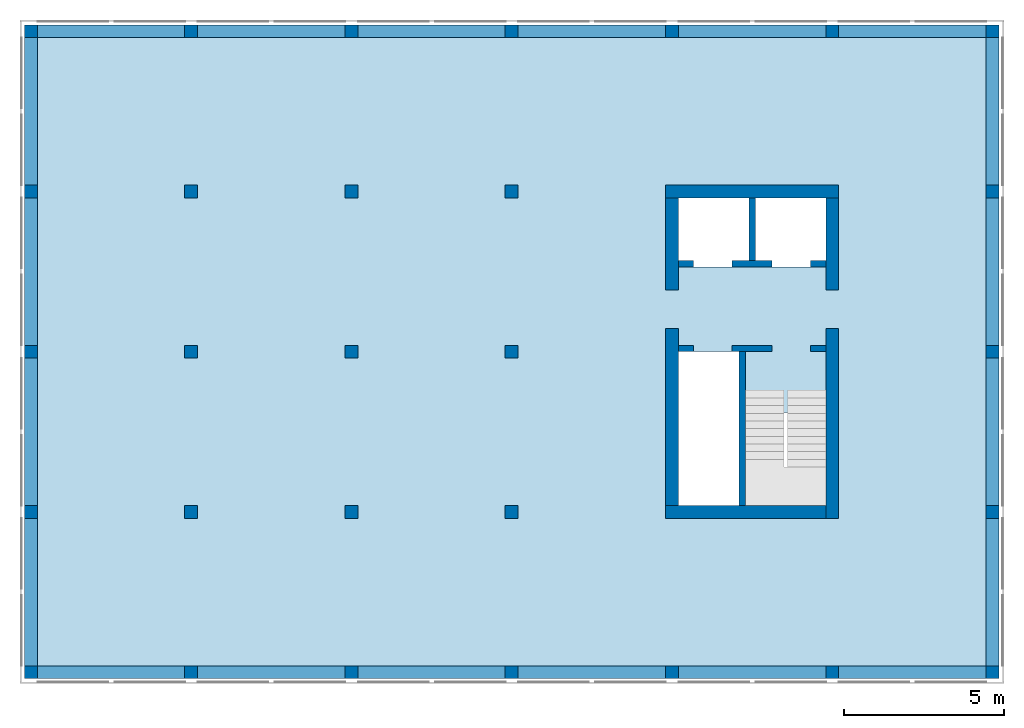
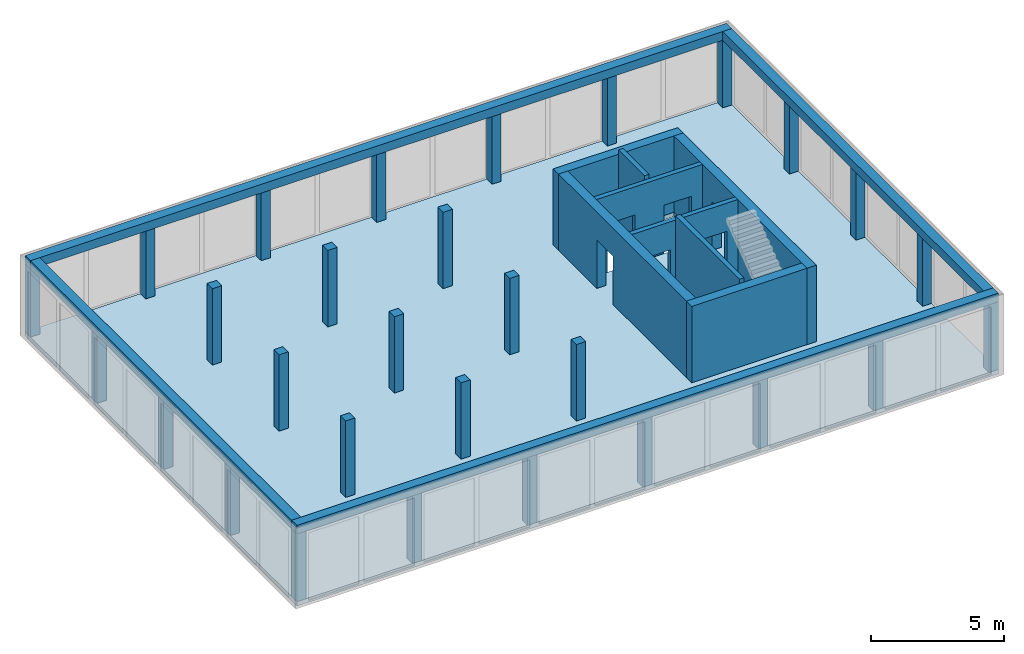
# One storey, part 1 of 4: 29 columns, 8 walls, 4 beams, 1 slab, 9 openings.
"""IFC2X3 building model written with IfcOpenShell, lengths in metres."""

from ifc_helpers import new_model, entity, si_unit, converted_unit, frame, frame_2d, origin, origin_with_axes, place, context, subcontext, project, spatial, polyline, rectangle, outline, extrude, material, layer, layer_set, layer_usage, element, save


model = new_model("IFC2X3")

# Units and contexts
model_context = context("Model", 3, precision=1e-05, world=origin())
body_context = subcontext(model_context, "Body", "Model", "MODEL_VIEW")
ifc_project = project(units=[si_unit("LENGTHUNIT", "METRE"), si_unit("AREAUNIT", "SQUARE_METRE"), si_unit("VOLUMEUNIT", "CUBIC_METRE"), si_unit("MASSUNIT", "GRAM", prefix="KILO"), converted_unit("PLANEANGLEUNIT", "DEGREE", entity("IfcPlaneAngleMeasure", 0.0174532925199433), si_unit("PLANEANGLEUNIT", "RADIAN"), dimensions=[0, 0, 0, 0, 0, 0, 0])], contexts=[model_context])

# Site, building, storey
site_placement = place(None, origin())
site = spatial("IfcSite", under=ifc_project, at=site_placement, CompositionType="ELEMENT")
building_placement = place(site_placement, origin())
building = spatial("IfcBuilding", under=site, at=building_placement, CompositionType="ELEMENT")
storey_placement = place(building_placement, frame((0.0, 0.0, 4.9)))
storey = spatial("IfcBuildingStorey", under=building, at=storey_placement, Name="1. Obergeschoss", CompositionType="ELEMENT", Elevation=4.9)

# Columns
ifc_material_1 = material(Name="C30/37")
column_1_placement = place(storey_placement, frame((5.0, 15.0, 0.0)))
element("IfcColumn", 1, at=column_1_placement, inside=storey, material=ifc_material_1, context=body_context, shape_type="SweptSolid", body=[
    extrude(rectangle(XDim=0.4, YDim=0.4, at=frame_2d((0.2, 0.2), x_axis=(1.0, 0.0))), origin_with_axes(), (0.0, 0.0, 1.0), 3.5),
])
ifc_material_2 = material(Name="C30/37")
column_2_placement = place(storey_placement, frame((10.0, 5.0, 0.0)))
element("IfcColumn", 2, at=column_2_placement, inside=storey, material=ifc_material_2, context=body_context, shape_type="SweptSolid", body=[
    extrude(rectangle(XDim=0.4, YDim=0.4, at=frame_2d((0.2, 0.2), x_axis=(1.0, 0.0))), origin_with_axes(), (0.0, 0.0, 1.0), 3.5),
])
ifc_material_3 = material(Name="C30/37")
column_3_placement = place(storey_placement, frame((15.0, 5.0, 0.0)))
element("IfcColumn", 3, at=column_3_placement, inside=storey, material=ifc_material_3, context=body_context, shape_type="SweptSolid", body=[
    extrude(rectangle(XDim=0.4, YDim=0.4, at=frame_2d((0.2, 0.2), x_axis=(1.0, 0.0))), origin_with_axes(), (0.0, 0.0, 1.0), 3.5),
])
ifc_material_4 = material(Name="C30/37")
column_4_placement = place(storey_placement, frame((5.0, 10.0, 0.0)))
element("IfcColumn", 4, at=column_4_placement, inside=storey, material=ifc_material_4, context=body_context, shape_type="SweptSolid", body=[
    extrude(rectangle(XDim=0.4, YDim=0.4, at=frame_2d((0.2, 0.2), x_axis=(1.0, 0.0))), origin_with_axes(), (0.0, 0.0, 1.0), 3.5),
])
ifc_material_5 = material(Name="C30/37")
column_5_placement = place(storey_placement, frame((10.0, 10.0, 0.0)))
element("IfcColumn", 5, at=column_5_placement, inside=storey, material=ifc_material_5, context=body_context, shape_type="SweptSolid", body=[
    extrude(rectangle(XDim=0.4, YDim=0.4, at=frame_2d((0.2, 0.2), x_axis=(1.0, 0.0))), origin_with_axes(), (0.0, 0.0, 1.0), 3.5),
])
ifc_material_6 = material(Name="C30/37")
column_6_placement = place(storey_placement, frame((15.0, 10.0, 0.0)))
element("IfcColumn", 6, at=column_6_placement, inside=storey, material=ifc_material_6, context=body_context, shape_type="SweptSolid", body=[
    extrude(rectangle(XDim=0.4, YDim=0.4, at=frame_2d((0.2, 0.2), x_axis=(1.0, 0.0))), origin_with_axes(), (0.0, 0.0, 1.0), 3.5),
])
ifc_material_7 = material(Name="C30/37")
column_7_placement = place(storey_placement, frame((10.0, 15.0, 0.0)))
element("IfcColumn", 7, at=column_7_placement, inside=storey, material=ifc_material_7, context=body_context, shape_type="SweptSolid", body=[
    extrude(rectangle(XDim=0.4, YDim=0.4, at=frame_2d((0.2, 0.2), x_axis=(1.0, 0.0))), origin_with_axes(), (0.0, 0.0, 1.0), 3.5),
])
ifc_material_8 = material(Name="C30/37")
column_8_placement = place(storey_placement, frame((15.0, 15.0, 0.0)))
element("IfcColumn", 8, at=column_8_placement, inside=storey, material=ifc_material_8, context=body_context, shape_type="SweptSolid", body=[
    extrude(rectangle(XDim=0.4, YDim=0.4, at=frame_2d((0.2, 0.2), x_axis=(1.0, 0.0))), origin_with_axes(), (0.0, 0.0, 1.0), 3.5),
])
ifc_material_9 = material(Name="C30/37")
column_9_placement = place(storey_placement, frame((5.0, 5.0, 0.0)))
element("IfcColumn", 9, at=column_9_placement, inside=storey, material=ifc_material_9, context=body_context, shape_type="SweptSolid", body=[
    extrude(rectangle(XDim=0.4, YDim=0.4, at=frame_2d((0.2, 0.2), x_axis=(1.0, 0.0))), origin_with_axes(), (0.0, 0.0, 1.0), 3.5),
])
ifc_material_10 = material(Name="C30/37")
column_10_placement = place(storey_placement, frame((30.0, 5.0, 0.0)))
element("IfcColumn", 10, at=column_10_placement, inside=storey, material=ifc_material_10, context=body_context, shape_type="SweptSolid", body=[
    extrude(rectangle(XDim=0.4, YDim=0.4, at=frame_2d((0.2, 0.2), x_axis=(1.0, 0.0))), origin_with_axes(), (0.0, 0.0, 1.0), 3.1),
])
ifc_material_11 = material(Name="C30/37")
column_11_placement = place(storey_placement, frame((30.0, 20.0, 0.0)))
element("IfcColumn", 11, at=column_11_placement, inside=storey, material=ifc_material_11, context=body_context, shape_type="SweptSolid", body=[
    extrude(rectangle(XDim=0.4, YDim=0.4, at=frame_2d((0.2, 0.2), x_axis=(1.0, 0.0))), origin_with_axes(), (0.0, 0.0, 1.0), 3.1),
])
ifc_material_12 = material(Name="C30/37")
column_12_placement = place(storey_placement, frame((30.0, 15.0, 0.0)))
element("IfcColumn", 12, at=column_12_placement, inside=storey, material=ifc_material_12, context=body_context, shape_type="SweptSolid", body=[
    extrude(rectangle(XDim=0.4, YDim=0.4, at=frame_2d((0.2, 0.2), x_axis=(1.0, 0.0))), origin_with_axes(), (0.0, 0.0, 1.0), 3.1),
])
ifc_material_13 = material(Name="C30/37")
column_13_placement = place(storey_placement, frame((30.0, 10.0, 0.0)))
element("IfcColumn", 13, at=column_13_placement, inside=storey, material=ifc_material_13, context=body_context, shape_type="SweptSolid", body=[
    extrude(rectangle(XDim=0.4, YDim=0.4, at=frame_2d((0.2, 0.2), x_axis=(1.0, 0.0))), origin_with_axes(), (0.0, 0.0, 1.0), 3.1),
])
ifc_material_14 = material(Name="C30/37")
column_14_placement = place(storey_placement, frame((25.0, 0.0, 0.0)))
element("IfcColumn", 14, at=column_14_placement, inside=storey, material=ifc_material_14, context=body_context, shape_type="SweptSolid", body=[
    extrude(rectangle(XDim=0.4, YDim=0.4, at=frame_2d((0.2, 0.2), x_axis=(1.0, 0.0))), origin_with_axes(), (0.0, 0.0, 1.0), 3.1),
])
ifc_material_15 = material(Name="C30/37")
column_15_placement = place(storey_placement, frame((20.0, 0.0, 0.0)))
element("IfcColumn", 15, at=column_15_placement, inside=storey, material=ifc_material_15, context=body_context, shape_type="SweptSolid", body=[
    extrude(rectangle(XDim=0.4, YDim=0.4, at=frame_2d((0.2, 0.2), x_axis=(1.0, 0.0))), origin_with_axes(), (0.0, 0.0, 1.0), 3.1),
])
ifc_material_16 = material(Name="C30/37")
column_16_placement = place(storey_placement, frame((15.0, 0.0, 0.0)))
element("IfcColumn", 16, at=column_16_placement, inside=storey, material=ifc_material_16, context=body_context, shape_type="SweptSolid", body=[
    extrude(rectangle(XDim=0.4, YDim=0.4, at=frame_2d((0.2, 0.2), x_axis=(1.0, 0.0))), origin_with_axes(), (0.0, 0.0, 1.0), 3.1),
])
ifc_material_17 = material(Name="C30/37")
column_17_placement = place(storey_placement, frame((10.0, 0.0, 0.0)))
element("IfcColumn", 17, at=column_17_placement, inside=storey, material=ifc_material_17, context=body_context, shape_type="SweptSolid", body=[
    extrude(rectangle(XDim=0.4, YDim=0.4, at=frame_2d((0.2, 0.2), x_axis=(1.0, 0.0))), origin_with_axes(), (0.0, 0.0, 1.0), 3.1),
])
ifc_material_18 = material(Name="C30/37")
column_18_placement = place(storey_placement, frame((5.0, 0.0, 0.0)))
element("IfcColumn", 18, at=column_18_placement, inside=storey, material=ifc_material_18, context=body_context, shape_type="SweptSolid", body=[
    extrude(rectangle(XDim=0.4, YDim=0.4, at=frame_2d((0.2, 0.2), x_axis=(1.0, 0.0))), origin_with_axes(), (0.0, 0.0, 1.0), 3.1),
])
ifc_material_19 = material(Name="C30/37")
column_19_placement = place(storey_placement, frame((-1.27897692436818e-15, 10.0, 0.0)))
element("IfcColumn", 19, at=column_19_placement, inside=storey, material=ifc_material_19, context=body_context, shape_type="SweptSolid", body=[
    extrude(rectangle(XDim=0.400000000000003, YDim=0.4, at=frame_2d((0.200000000000001, 0.2), x_axis=(1.0, 0.0))), origin_with_axes(), (0.0, 0.0, 1.0), 3.1),
])
ifc_material_20 = material(Name="C30/37")
column_20_placement = place(storey_placement, frame((0.0, 15.0, 0.0)))
element("IfcColumn", 20, at=column_20_placement, inside=storey, material=ifc_material_20, context=body_context, shape_type="SweptSolid", body=[
    extrude(rectangle(XDim=0.4, YDim=0.4, at=frame_2d((0.2, 0.2), x_axis=(1.0, 0.0))), origin_with_axes(), (0.0, 0.0, 1.0), 3.1),
])
ifc_material_21 = material(Name="C30/37")
column_21_placement = place(storey_placement, frame((0.0, 5.0, 0.0)))
element("IfcColumn", 21, at=column_21_placement, inside=storey, material=ifc_material_21, context=body_context, shape_type="SweptSolid", body=[
    extrude(rectangle(XDim=0.4, YDim=0.4, at=frame_2d((0.2, 0.2), x_axis=(1.0, 0.0))), origin_with_axes(), (0.0, 0.0, 1.0), 3.1),
])
ifc_material_22 = material(Name="C30/37")
column_22_placement = place(storey_placement, origin())
element("IfcColumn", 22, at=column_22_placement, inside=storey, material=ifc_material_22, context=body_context, shape_type="SweptSolid", body=[
    extrude(rectangle(XDim=0.4, YDim=0.4, at=frame_2d((0.2, 0.2), x_axis=(1.0, 0.0))), origin_with_axes(), (0.0, 0.0, 1.0), 3.1),
])
ifc_material_23 = material(Name="C30/37")
column_23_placement = place(storey_placement, frame((0.0, 20.0, 0.0)))
element("IfcColumn", 23, at=column_23_placement, inside=storey, material=ifc_material_23, context=body_context, shape_type="SweptSolid", body=[
    extrude(rectangle(XDim=0.4, YDim=0.4, at=frame_2d((0.2, 0.2), x_axis=(1.0, 0.0))), origin_with_axes(), (0.0, 0.0, 1.0), 3.1),
])
ifc_material_24 = material(Name="C30/37")
column_24_placement = place(storey_placement, frame((20.0, 20.0, 0.0)))
element("IfcColumn", 24, at=column_24_placement, inside=storey, material=ifc_material_24, context=body_context, shape_type="SweptSolid", body=[
    extrude(rectangle(XDim=0.4, YDim=0.4, at=frame_2d((0.2, 0.2), x_axis=(1.0, 0.0))), origin_with_axes(), (0.0, 0.0, 1.0), 3.1),
])
ifc_material_25 = material(Name="C30/37")
column_25_placement = place(storey_placement, frame((15.0, 20.0, 0.0)))
element("IfcColumn", 25, at=column_25_placement, inside=storey, material=ifc_material_25, context=body_context, shape_type="SweptSolid", body=[
    extrude(rectangle(XDim=0.4, YDim=0.4, at=frame_2d((0.2, 0.2), x_axis=(1.0, 0.0))), origin_with_axes(), (0.0, 0.0, 1.0), 3.1),
])
ifc_material_26 = material(Name="C30/37")
column_26_placement = place(storey_placement, frame((10.0, 20.0, 0.0)))
element("IfcColumn", 26, at=column_26_placement, inside=storey, material=ifc_material_26, context=body_context, shape_type="SweptSolid", body=[
    extrude(rectangle(XDim=0.4, YDim=0.4, at=frame_2d((0.2, 0.2), x_axis=(1.0, 0.0))), origin_with_axes(), (0.0, 0.0, 1.0), 3.1),
])
ifc_material_27 = material(Name="C30/37")
column_27_placement = place(storey_placement, frame((25.0, 20.0, 0.0)))
element("IfcColumn", 27, at=column_27_placement, inside=storey, material=ifc_material_27, context=body_context, shape_type="SweptSolid", body=[
    extrude(rectangle(XDim=0.4, YDim=0.4, at=frame_2d((0.2, 0.2), x_axis=(1.0, 0.0))), origin_with_axes(), (0.0, 0.0, 1.0), 3.1),
])
ifc_material_28 = material(Name="C30/37")
column_28_placement = place(storey_placement, frame((5.0, 20.0, 0.0)))
element("IfcColumn", 28, at=column_28_placement, inside=storey, material=ifc_material_28, context=body_context, shape_type="SweptSolid", body=[
    extrude(rectangle(XDim=0.4, YDim=0.4, at=frame_2d((0.2, 0.2), x_axis=(1.0, 0.0))), origin_with_axes(), (0.0, 0.0, 1.0), 3.1),
])
ifc_material_29 = material(Name="C30/37")
column_29_placement = place(storey_placement, frame((30.0, -2.8421709430404e-17, 0.0)))
element("IfcColumn", 29, at=column_29_placement, inside=storey, material=ifc_material_29, context=body_context, shape_type="SweptSolid", body=[
    extrude(rectangle(XDim=0.4, YDim=0.4, at=frame_2d((0.2, 0.2), x_axis=(1.0, 0.0))), origin_with_axes(), (0.0, 0.0, 1.0), 3.1),
])

# Beams
ifc_material_30 = material(Name="C30/37")
beam_1_placement = place(storey_placement, frame((30.4, 0.4, 3.1), z_axis=(0.0, 0.0, 1.0), x_axis=(0.0, 1.0, 0.0)))
element("IfcBeam", 30, at=beam_1_placement, inside=storey, material=ifc_material_30, context=body_context, shape_type="SweptSolid", body=[
    extrude(rectangle(XDim=0.4, YDim=0.4, at=frame_2d((0.2, 0.2), x_axis=(1.0, 0.0))), frame((0.0, 0.0, 0.0), z_axis=(1.0, 0.0, 0.0), x_axis=(0.0, 1.0, 0.0)), (0.0, 0.0, 1.0), 19.6),
])
ifc_material_31 = material(Name="C30/37")
beam_2_placement = place(storey_placement, frame((-2.8421709430404e-17, 20.0, 3.1), z_axis=(0.0, 0.0, 1.0), x_axis=(2.90017443167388e-18, -1.0, 0.0)))
element("IfcBeam", 31, at=beam_2_placement, inside=storey, material=ifc_material_31, context=body_context, shape_type="SweptSolid", body=[
    extrude(rectangle(XDim=0.4, YDim=0.4, at=frame_2d((0.2, 0.2), x_axis=(1.0, 0.0))), frame((0.0, 0.0, 0.0), z_axis=(1.0, 0.0, 0.0), x_axis=(0.0, 1.0, 0.0)), (0.0, 0.0, 1.0), 19.6),
])
ifc_material_32 = material(Name="C30/37")
beam_3_placement = place(storey_placement, frame((2.95817792030736e-17, 2.8421709430404e-17, 3.1), z_axis=(0.0, 0.0, 1.0), x_axis=(1.0, -1.86984930463184e-18, 0.0)))
element("IfcBeam", 32, at=beam_3_placement, inside=storey, material=ifc_material_32, context=body_context, shape_type="SweptSolid", body=[
    extrude(rectangle(XDim=0.4, YDim=0.4, at=frame_2d((0.2, 0.2), x_axis=(1.0, 0.0))), frame((0.0, 0.0, 0.0), z_axis=(1.0, 0.0, 0.0), x_axis=(0.0, 1.0, 0.0)), (0.0, 0.0, 1.0), 30.4),
])
ifc_material_33 = material(Name="C30/37")
beam_4_placement = place(storey_placement, frame((-2.8421709430404e-17, 20.0, 3.1)))
element("IfcBeam", 33, at=beam_4_placement, inside=storey, material=ifc_material_33, context=body_context, shape_type="SweptSolid", body=[
    extrude(rectangle(XDim=0.4, YDim=0.4, at=frame_2d((0.2, 0.2), x_axis=(1.0, 0.0))), frame((0.0, 0.0, 0.0), z_axis=(1.0, 0.0, 0.0), x_axis=(0.0, 1.0, 0.0)), (0.0, 0.0, 1.0), 30.4),
])

# Slab, openings
ifc_material_34 = material(Name="C25/30")
slab_placement = place(storey_placement, frame((0.0, -2.8421709430404e-17, -0.2)))
slab = element("IfcSlab", 34, at=slab_placement, inside=storey, material=ifc_material_34, Name="Geschossdecke", PredefinedType="FLOOR", context=body_context, shape_type="SweptSolid", body=[
    extrude(rectangle(XDim=30.4, YDim=20.4, at=frame_2d((15.2, 10.2), x_axis=(1.0, -9.34924652315921e-19))), frame((0.0, 2.8421709430404e-17, 0.0), z_axis=(0.0, 0.0, 1.0), x_axis=(1.0, 0.0, 0.0)), (0.0, 0.0, 1.0), 0.2),
])
opening_1_placement = place(slab_placement, frame((22.5, 5.4, 0.0)))
element("IfcOpeningElement", 35, at=opening_1_placement, cuts=slab, ObjectType="Opening", context=body_context, shape_type="SweptSolid", body=[
    extrude(rectangle(XDim=2.90000000000001, YDim=2.5, at=frame_2d((0.0, 0.0), x_axis=(0.0, -1.0))), frame((1.25, 1.45, 0.0), z_axis=(0.0, 0.0, 1.0), x_axis=(1.0, 0.0, 0.0)), (0.0, 0.0, 1.0), 0.2),
])
opening_2_placement = place(slab_placement, frame((20.4, 5.4, 0.0)))
element("IfcOpeningElement", 36, at=opening_2_placement, cuts=slab, ObjectType="Opening", context=body_context, shape_type="SweptSolid", body=[
    extrude(rectangle(XDim=2.1, YDim=4.8, at=frame_2d((1.81898940354586e-15, 0.0), x_axis=(-1.0, 0.0))), frame((1.05, 2.4, 0.0), z_axis=(0.0, 0.0, 1.0), x_axis=(1.0, 0.0, 0.0)), (0.0, 0.0, 1.0), 0.2),
])
opening_3_placement = place(slab_placement, frame((20.4, 12.85, 0.0)))
element("IfcOpeningElement", 37, at=opening_3_placement, cuts=slab, ObjectType="Opening", context=body_context, shape_type="SweptSolid", body=[
    extrude(rectangle(XDim=2.15, YDim=4.6, at=frame_2d((1.81898940354586e-15, 0.0), x_axis=(0.0, -1.0))), frame((2.3, 1.075, 0.0), z_axis=(0.0, 0.0, 1.0), x_axis=(1.0, 0.0, 0.0)), (0.0, 0.0, 1.0), 0.2),
])

# Wall, opening
ifc_material_35 = material(Name="C25/30")
ifc_layer_1 = layer(ifc_material_35, 0.4)
ifc_layer_set_1 = layer_set([ifc_layer_1])
ifc_layer_usage_1 = layer_usage(ifc_layer_set_1, "AXIS2", "POSITIVE", -0.2)
wall_1_placement = place(storey_placement, frame((25.0, 15.0, 0.0), z_axis=(0.0, 0.0, 1.0), x_axis=(0.0, -1.0, 0.0)))
wall_1 = element("IfcWallStandardCase", 38, at=wall_1_placement, inside=storey, material=ifc_layer_usage_1, context=body_context, shape_type="SweptSolid", body=[
    extrude(rectangle(XDim=10.0, YDim=0.4, at=frame_2d((5.0, 0.2), x_axis=(1.0, 0.0))), origin_with_axes(), (0.0, 0.0, 1.0), 3.5),
])
opening_4_placement = place(wall_1_placement, frame((2.87, 0.0, 0.0), z_axis=(0.0, 1.0, 0.0), x_axis=(0.0, 0.0, 1.0)))
element("IfcOpeningElement", 39, at=opening_4_placement, cuts=wall_1, ObjectType="Opening", context=body_context, shape_type="SweptSolid", body=[
    extrude(outline(polyline([(0.0, 1.21), (2.21, 1.21), (2.21, 0.0), (0.0, 0.0), (0.0, 1.21)])), origin_with_axes(), (0.0, 0.0, 1.0), 0.4),
])

# Wall
ifc_material_36 = material(Name="C25/30")
ifc_layer_2 = layer(ifc_material_36, 0.4)
ifc_layer_set_2 = layer_set([ifc_layer_2])
ifc_layer_usage_2 = layer_usage(ifc_layer_set_2, "AXIS2", "POSITIVE", -0.2)
wall_2_placement = place(storey_placement, frame((20.0, 15.0, 0.0)))
element("IfcWallStandardCase", 40, at=wall_2_placement, inside=storey, material=ifc_layer_usage_2, context=body_context, shape_type="SweptSolid", body=[
    extrude(rectangle(XDim=5.4, YDim=0.4, at=frame_2d((2.7, 0.2), x_axis=(1.0, 0.0))), origin_with_axes(), (0.0, 0.0, 1.0), 3.5),
])

# Wall, openings
ifc_material_37 = material(Name="C25/30")
ifc_layer_3 = layer(ifc_material_37, 0.2)
ifc_layer_set_3 = layer_set([ifc_layer_3])
ifc_layer_usage_3 = layer_usage(ifc_layer_set_3, "AXIS2", "POSITIVE", -0.2)
wall_3_placement = place(storey_placement, frame((25.0, 13.05, 0.0), z_axis=(0.0, 0.0, 1.0), x_axis=(-1.0, 0.0, 0.0)))
wall_3 = element("IfcWallStandardCase", 41, at=wall_3_placement, inside=storey, material=ifc_layer_usage_3, Name="IW Beton", context=body_context, shape_type="SweptSolid", body=[
    extrude(rectangle(XDim=4.6, YDim=0.2, at=frame_2d((2.3, 0.1), x_axis=(1.0, 0.0))), origin_with_axes(), (0.0, 0.0, 1.0), 3.5),
])
opening_5_placement = place(wall_3_placement, frame((4.13, 0.2, 0.0), z_axis=(0.0, -1.0, 0.0), x_axis=(0.0, 0.0, 1.0)))
element("IfcOpeningElement", 42, at=opening_5_placement, cuts=wall_3, ObjectType="Opening", context=body_context, shape_type="SweptSolid", body=[
    extrude(outline(polyline([(0.0, 1.21), (2.21, 1.21), (2.21, 0.0), (0.0, 0.0), (0.0, 1.21)])), origin_with_axes(), (0.0, 0.0, 1.0), 0.2),
])
opening_6_placement = place(wall_3_placement, frame((1.68, 0.2, 0.0), z_axis=(0.0, -1.0, 0.0), x_axis=(0.0, 0.0, 1.0)))
element("IfcOpeningElement", 43, at=opening_6_placement, cuts=wall_3, ObjectType="Opening", context=body_context, shape_type="SweptSolid", body=[
    extrude(outline(polyline([(0.0, 1.21), (2.21, 1.21), (2.21, 0.0), (0.0, 0.0), (0.0, 1.21)])), origin_with_axes(), (0.0, 0.0, 1.0), 0.2),
])

ifc_material_38 = material(Name="C25/30")
ifc_layer_4 = layer(ifc_material_38, 0.2)
ifc_layer_set_4 = layer_set([ifc_layer_4])
ifc_layer_usage_4 = layer_usage(ifc_layer_set_4, "AXIS2", "POSITIVE", -0.2)
wall_4_placement = place(storey_placement, frame((25.0, 10.4, 0.0), z_axis=(0.0, 0.0, 1.0), x_axis=(-1.0, 0.0, 0.0)))
wall_4 = element("IfcWallStandardCase", 44, at=wall_4_placement, inside=storey, material=ifc_layer_usage_4, Name="IW Beton", context=body_context, shape_type="SweptSolid", body=[
    extrude(rectangle(XDim=4.6, YDim=0.2, at=frame_2d((2.3, 0.1), x_axis=(1.0, 0.0))), origin_with_axes(), (0.0, 0.0, 1.0), 3.5),
])
opening_7_placement = place(wall_4_placement, frame((1.68, 0.2, 0.0), z_axis=(0.0, -1.0, 0.0), x_axis=(0.0, 0.0, 1.0)))
element("IfcOpeningElement", 45, at=opening_7_placement, cuts=wall_4, ObjectType="Opening", context=body_context, shape_type="SweptSolid", body=[
    extrude(outline(polyline([(0.0, 1.21), (2.21, 1.21), (2.21, 0.0), (0.0, 0.0), (0.0, 1.21)])), origin_with_axes(), (0.0, 0.0, 1.0), 0.2),
])
opening_8_placement = place(wall_4_placement, frame((4.13, 0.2, 0.0), z_axis=(0.0, -1.0, 0.0), x_axis=(0.0, 0.0, 1.0)))
element("IfcOpeningElement", 46, at=opening_8_placement, cuts=wall_4, ObjectType="Opening", context=body_context, shape_type="SweptSolid", body=[
    extrude(outline(polyline([(0.0, 1.21), (2.21, 1.21), (2.21, 0.0), (0.0, 0.0), (0.0, 1.21)])), origin_with_axes(), (0.0, 0.0, 1.0), 0.2),
])

# Walls
ifc_material_39 = material(Name="C25/30")
ifc_layer_5 = layer(ifc_material_39, 0.2)
ifc_layer_set_5 = layer_set([ifc_layer_5])
ifc_layer_usage_5 = layer_usage(ifc_layer_set_5, "AXIS2", "POSITIVE", -0.2)
wall_5_placement = place(storey_placement, frame((22.3, 10.2, 0.0), z_axis=(0.0, 0.0, 1.0), x_axis=(0.0, -1.0, 0.0)))
element("IfcWallStandardCase", 47, at=wall_5_placement, inside=storey, material=ifc_layer_usage_5, Name="IW Beton", context=body_context, shape_type="SweptSolid", body=[
    extrude(rectangle(XDim=4.8, YDim=0.2, at=frame_2d((2.4, 0.1), x_axis=(1.0, 0.0))), origin_with_axes(), (0.0, 0.0, 1.0), 3.7),
])
ifc_material_40 = material(Name="C25/30")
ifc_layer_6 = layer(ifc_material_40, 0.2)
ifc_layer_set_6 = layer_set([ifc_layer_6])
ifc_layer_usage_6 = layer_usage(ifc_layer_set_6, "AXIS2", "POSITIVE", -0.2)
wall_6_placement = place(storey_placement, frame((22.6, 15.0, 0.0), z_axis=(0.0, 0.0, 1.0), x_axis=(0.0, -1.0, 0.0)))
element("IfcWallStandardCase", 48, at=wall_6_placement, inside=storey, material=ifc_layer_usage_6, Name="IW Beton", context=body_context, shape_type="SweptSolid", body=[
    extrude(rectangle(XDim=1.95, YDim=0.2, at=frame_2d((0.975, 0.1), x_axis=(1.0, 0.0))), origin_with_axes(), (0.0, 0.0, 1.0), 3.7),
])
ifc_material_41 = material(Name="C25/30")
ifc_layer_7 = layer(ifc_material_41, 0.4)
ifc_layer_set_7 = layer_set([ifc_layer_7])
ifc_layer_usage_7 = layer_usage(ifc_layer_set_7, "AXIS2", "POSITIVE", -0.2)
wall_7_placement = place(storey_placement, frame((25.0, 5.4, 0.0), z_axis=(0.0, 0.0, 1.0), x_axis=(-1.0, 0.0, 0.0)))
element("IfcWallStandardCase", 49, at=wall_7_placement, inside=storey, material=ifc_layer_usage_7, context=body_context, shape_type="SweptSolid", body=[
    extrude(rectangle(XDim=5.0, YDim=0.4, at=frame_2d((2.5, 0.2), x_axis=(1.0, 0.0))), origin_with_axes(), (0.0, 0.0, 1.0), 3.5),
])

# Wall, opening
ifc_material_42 = material(Name="C25/30")
ifc_layer_8 = layer(ifc_material_42, 0.4)
ifc_layer_set_8 = layer_set([ifc_layer_8])
ifc_layer_usage_8 = layer_usage(ifc_layer_set_8, "AXIS2", "POSITIVE", -0.2)
wall_8_placement = place(storey_placement, frame((20.4, 5.4, 0.0), z_axis=(0.0, 0.0, 1.0), x_axis=(0.0, 1.0, 0.0)))
wall_8 = element("IfcWallStandardCase", 50, at=wall_8_placement, inside=storey, material=ifc_layer_usage_8, context=body_context, shape_type="SweptSolid", body=[
    extrude(rectangle(XDim=9.6, YDim=0.4, at=frame_2d((4.8, 0.2), x_axis=(1.0, 0.0))), origin_with_axes(), (0.0, 0.0, 1.0), 3.5),
])
opening_9_placement = place(wall_8_placement, frame((5.52, 0.0, 0.0), z_axis=(0.0, 1.0, 0.0), x_axis=(0.0, 0.0, 1.0)))
element("IfcOpeningElement", 51, at=opening_9_placement, cuts=wall_8, ObjectType="Opening", context=body_context, shape_type="SweptSolid", body=[
    extrude(outline(polyline([(0.0, 1.21), (2.21, 1.21), (2.21, 0.0), (0.0, 0.0), (0.0, 1.21)])), origin_with_axes(), (0.0, 0.0, 1.0), 0.4),
])

save(model, "model.ifc")
